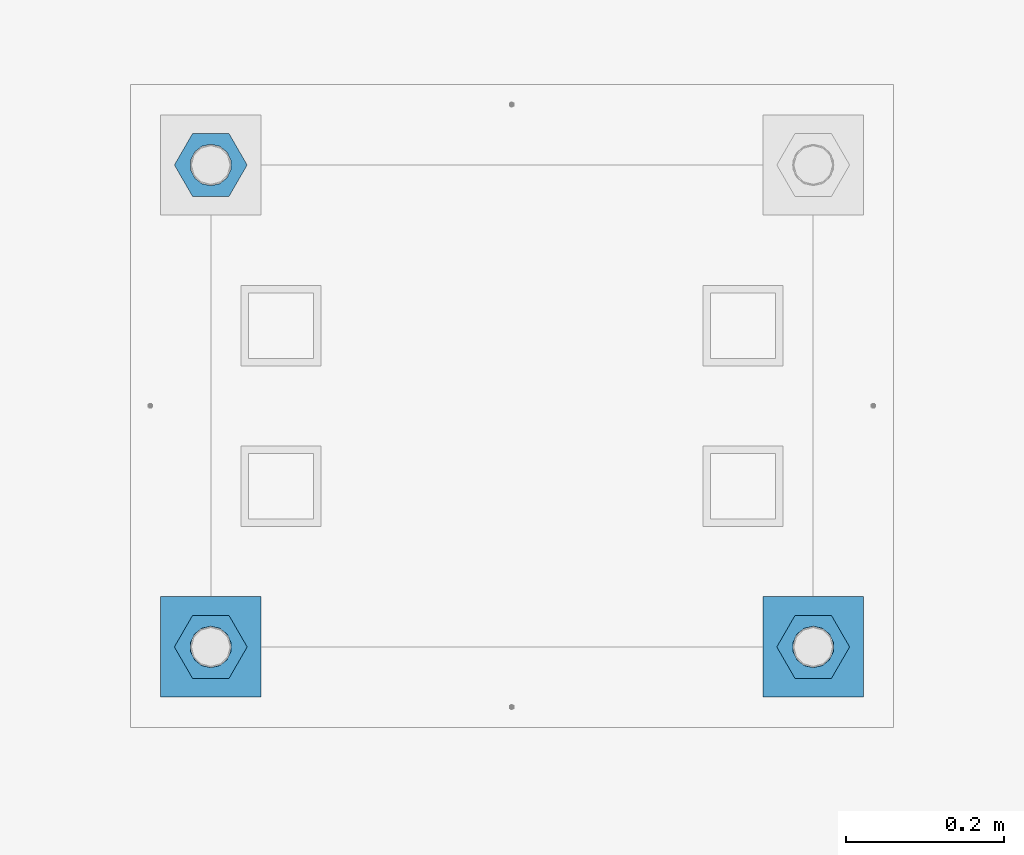
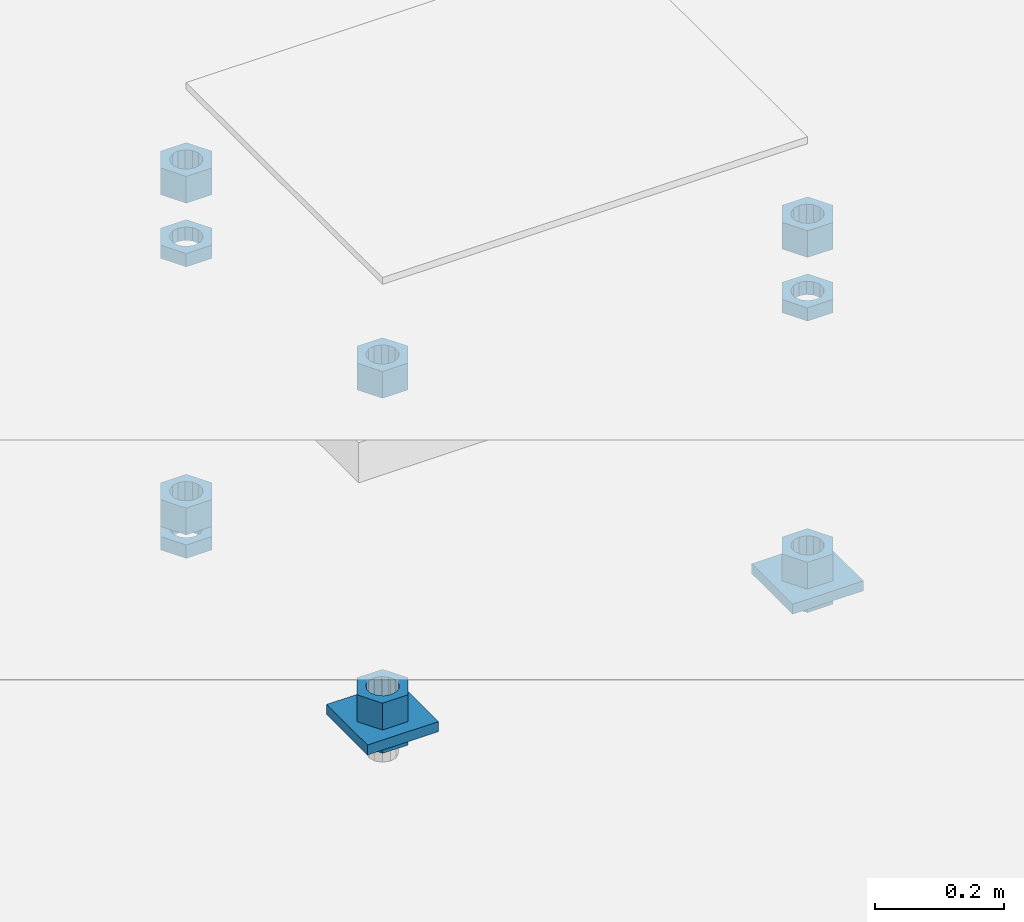
# One storey, part 2667 of 3843: 13 beams, 1 element without a shape of its own.
"""IFC2X3 building model written with IfcOpenShell, lengths in millimetres."""

import ifcopenshell
import ifcopenshell.guid

model = None  # the IFC model being written
_history = None  # IfcOwnerHistory: only IFC2X3 demands one
_inside = {}  # id of a spatial element -> (the spatial element, [elements in it])
_under = {}  # id of a project, library or spatial element -> (it, [spatial elements below it])
_declared = {}  # id of a project -> (the project, [libraries it declares])
_typed = {}  # id of a type object -> (the type object, [elements of that type])
_made_of = {}  # id of a material, layer set ... -> (it, [elements and type objects made of it])


def new_model(schema):
    """Start an empty IFC model of exactly this schema.

    Asked for "IFC4X3", IfcOpenShell would pick the latest addendum, in which some entities
    have other attributes; the version numbers below select the first issue.
    IFC2X3 requires an IfcOwnerHistory on every rooted entity: one is made here for all.
    """
    global model, _history
    if schema == "IFC4X3":
        model = ifcopenshell.file(schema_version=(4, 3, 0, 0))
    else:
        model = ifcopenshell.file(schema=schema)
    _inside.clear()
    _under.clear()
    _declared.clear()
    _typed.clear()
    _made_of.clear()
    _history = None
    if model.schema == "IFC2X3":
        org = make("IfcOrganization", Name="unknown")
        user = make(
            "IfcPersonAndOrganization",
            ThePerson=make("IfcPerson", FamilyName="unknown"),
            TheOrganization=org,
        )
        app = make(
            "IfcApplication",
            ApplicationDeveloper=org,
            Version="unknown",
            ApplicationFullName="unknown",
            ApplicationIdentifier="unknown",
        )
        _history = make(
            "IfcOwnerHistory",
            OwningUser=user,
            OwningApplication=app,
            ChangeAction="ADDED",
            CreationDate=0,
        )
    return model


def make(cls, **values):
    """One entity of the class cls with the attributes given. An attribute that is None is left unset."""
    return model.create_entity(
        cls, **{name: value for name, value in values.items() if value is not None}
    )


def rooted(cls, **values):
    """An entity with a GlobalId (a new one), such as an element, a storey or a relation."""
    return make(cls, GlobalId=ifcopenshell.guid.new(), OwnerHistory=_history, **values)


def si_unit(unit_type, name, prefix=None):
    """IfcSIUnit, for example si_unit("LENGTHUNIT", "METRE", prefix="MILLI")."""
    return make("IfcSIUnit", UnitType=unit_type, Prefix=prefix, Name=name)


def assignment(units):
    """IfcUnitAssignment: the units of a project."""
    return None if units is None else make("IfcUnitAssignment", Units=units)


def point(xyz):
    """IfcCartesianPoint."""
    return None if xyz is None else make("IfcCartesianPoint", Coordinates=xyz)


def direction(xyz):
    """IfcDirection."""
    return None if xyz is None else make("IfcDirection", DirectionRatios=xyz)


def frame(location, z_axis=None, x_axis=None):
    """IfcAxis2Placement3D, a coordinate frame: its origin and axes. An axis left out is left unset."""
    return make(
        "IfcAxis2Placement3D",
        Location=point(location),
        Axis=direction(z_axis),
        RefDirection=direction(x_axis),
    )


def origin_with_axes():
    """The frame at (0, 0, 0) with the z axis (0, 0, 1) and the x axis (1, 0, 0) written out."""
    return frame((0.0, 0.0, 0.0), z_axis=(0.0, 0.0, 1.0), x_axis=(1.0, 0.0, 0.0))


def place(relative_to, where):
    """IfcLocalPlacement: puts the frame where relative to a parent placement (None: the world)."""
    return make(
        "IfcLocalPlacement", PlacementRelTo=relative_to, RelativePlacement=where
    )


def context(
    kind, dimensions, precision=None, world=None, true_north=None, identifier=None
):
    """IfcGeometricRepresentationContext, for example the 3D "Model" context."""
    return make(
        "IfcGeometricRepresentationContext",
        ContextIdentifier=identifier,
        ContextType=kind,
        CoordinateSpaceDimension=dimensions,
        Precision=precision,
        WorldCoordinateSystem=world,
        TrueNorth=true_north,
    )


def subcontext(parent, identifier, kind, view, scale=None):
    """IfcGeometricRepresentationSubContext, for example "Body" below "Model"."""
    return make(
        "IfcGeometricRepresentationSubContext",
        ContextIdentifier=identifier,
        ContextType=kind,
        ParentContext=parent,
        TargetScale=scale,
        TargetView=view,
    )


def project(units=None, contexts=None):
    """IfcProject with its units and contexts."""
    return rooted(
        "IfcProject",
        Name="project",
        RepresentationContexts=contexts,
        UnitsInContext=assignment(units),
    )


def spatial(cls, under=None, at=None, **own):
    """A site, building, storey or space (cls), placed at a placement, below another one or the project."""
    s = rooted(cls, ObjectPlacement=at, **own)
    if under is not None:
        _under.setdefault(under.id(), (under, []))[1].append(s)
    return s


def faces_of(points, faces, orient=None, outer=None):
    """IfcFace entities. A face is a list of loops; a loop is a list of indices into points, from 0.

    orient and outer hold one flag for each loop. By default every Orientation is true, the
    first loop of a face is its IfcFaceOuterBound and the others are IfcFaceBound.
    """
    made = []
    for i, loops in enumerate(faces):
        bounds = []
        for j, loop in enumerate(loops):
            is_outer = j == 0 if outer is None else outer[i][j]
            bounds.append(
                make(
                    "IfcFaceOuterBound" if is_outer else "IfcFaceBound",
                    Bound=make("IfcPolyLoop", Polygon=[points[k] for k in loop]),
                    Orientation=True if orient is None else orient[i][j],
                )
            )
        made.append(make("IfcFace", Bounds=bounds))
    return made


def faceted_brep(points, faces, orient=None, outer=None, voids=None):
    """IfcFacetedBrep: a solid bounded by flat faces; with voids (closed shells), ...WithVoids."""
    shared = [point(p) for p in points]
    hull = make("IfcClosedShell", CfsFaces=faces_of(shared, faces, orient, outer))
    if voids is None:
        return make("IfcFacetedBrep", Outer=hull)
    return make(
        "IfcFacetedBrepWithVoids",
        Outer=hull,
        Voids=[
            make(cls, CfsFaces=faces_of(shared, fs, o, b)) for cls, fs, o, b in voids
        ],
    )


def shape(context_of_items, identifier, shape_type, items):
    """IfcShapeRepresentation: the items that make up one representation, for example the "Body"."""
    return make(
        "IfcShapeRepresentation",
        ContextOfItems=context_of_items,
        RepresentationIdentifier=identifier,
        RepresentationType=shape_type,
        Items=items,
    )


def material(Name=None, Category=None):
    """IfcMaterial."""
    return make("IfcMaterial", Name=Name, Category=Category)


def made_of(thing, what):
    """Note that an element or type object is made of a material, layer set ...; save() writes the relation."""
    if what is not None:
        _made_of.setdefault(what.id(), (what, []))[1].append(thing)
    return thing


def type_object(cls, material=None, **own):
    """A type object (cls), such as IfcWallType, which elements share."""
    return made_of(rooted(cls, **own), material)


def element(
    cls,
    number,
    at=None,
    inside=None,
    cuts=None,
    type_object=None,
    material=None,
    context=None,
    identifier="Body",
    shape_type=None,
    held_by="IfcProductDefinitionShape",
    body=None,
    shapes=None,
    **own,
):
    """One element of the class cls, such as IfcWall. Its Tag is "e" and its number.

    at: its placement. inside: the storey or other place that contains it. cuts: it is an
    opening in that element (IfcRelVoidsElement). A single representation is given by context,
    identifier, shape_type and body (its items); several are given by shapes. held_by: the class
    of the entity that holds the representations. save() writes the other relations.
    """
    e = rooted(cls, Tag="e%d" % number, ObjectPlacement=at, **own)
    if body is not None:
        shapes = [shape(context, identifier, shape_type, body)]
    if shapes is not None:
        e.Representation = make(held_by, Representations=shapes)
    if inside is not None:
        _inside.setdefault(inside.id(), (inside, []))[1].append(e)
    if cuts is not None:
        rooted(
            "IfcRelVoidsElement", RelatingBuildingElement=cuts, RelatedOpeningElement=e
        )
    if type_object is not None:
        _typed.setdefault(type_object.id(), (type_object, []))[1].append(e)
    return made_of(e, material)


def aggregate(whole, parts):
    """IfcRelAggregates: a whole, such as a stair, and the parts it consists of."""
    return rooted("IfcRelAggregates", RelatingObject=whole, RelatedObjects=parts)


def save(model, path):
    """Write the relations noted so far, then the file.

    IfcRelAggregates (storeys below a building ...), IfcRelContainedInSpatialStructure (elements
    in a storey), IfcRelDefinesByType, IfcRelAssociatesMaterial and IfcRelDeclares: one each for
    every whole, place, type object, material and project.
    """
    for whole, parts in _under.values():
        aggregate(whole, parts)
    for where, things in _inside.values():
        rooted(
            "IfcRelContainedInSpatialStructure",
            RelatedElements=things,
            RelatingStructure=where,
        )
    for kind, things in _typed.values():
        rooted("IfcRelDefinesByType", RelatedObjects=things, RelatingType=kind)
    for what, things in _made_of.values():
        rooted("IfcRelAssociatesMaterial", RelatedObjects=things, RelatingMaterial=what)
    for by, libraries in _declared.values():
        rooted("IfcRelDeclares", RelatingContext=by, RelatedDefinitions=libraries)
    model.write(path)


model = new_model("IFC2X3")

# Units and contexts
model_context = context("Model", 3, precision=1e-05, world=origin_with_axes())
body_context = subcontext(model_context, "Body", "Model", "MODEL_VIEW")
ifc_project = project(units=[si_unit("LENGTHUNIT", "METRE", prefix="MILLI"), si_unit("AREAUNIT", "SQUARE_METRE"), si_unit("VOLUMEUNIT", "CUBIC_METRE"), si_unit("MASSUNIT", "GRAM", prefix="KILO"), si_unit("TIMEUNIT", "SECOND"), si_unit("PLANEANGLEUNIT", "RADIAN"), si_unit("SOLIDANGLEUNIT", "STERADIAN"), si_unit("THERMODYNAMICTEMPERATUREUNIT", "DEGREE_CELSIUS"), si_unit("LUMINOUSINTENSITYUNIT", "LUMEN")], contexts=[model_context])

# Site, building, storey
site_placement = place(None, origin_with_axes())
site = spatial("IfcSite", under=ifc_project, at=site_placement, CompositionType="ELEMENT")
building_placement = place(site_placement, origin_with_axes())
building = spatial("IfcBuilding", under=site, at=building_placement, Name="Undefined", CompositionType="ELEMENT")
storey_placement = place(building_placement, origin_with_axes())
storey = spatial("IfcBuildingStorey", under=building, at=storey_placement, Name="Undefined", CompositionType="ELEMENT", Elevation=0.0)

# Assembly, beams
assembly_placement = place(storey_placement, origin_with_axes())
assembly = element("IfcElementAssembly", 1, at=assembly_placement, inside=storey, Name="TEMPLATE", AssemblyPlace="NOTDEFINED", PredefinedType="RIGID_FRAME")
ifc_material_1 = material(Name="STEEL/A572-50")
beam_type_1 = type_object("IfcBeamType", PredefinedType="NOTDEFINED")
beam_1_placement = place(assembly_placement, frame((118465.6, 21717.0000015259, 29244.925), z_axis=(1.0, 0.0, 0.0), x_axis=(0.0, 1.0, 0.0)))
beam_1 = element("IfcBeam", 2, at=beam_1_placement, type_object=beam_type_1, material=ifc_material_1, Name="WASHER_PLATE", context=body_context, shape_type="Brep", body=[
    faceted_brep([(0.0, 9.52500000000146, -63.5), (0.0, 9.52500000000146, 63.5), (127.0, 9.52500000000146, 63.5), (127.0, 9.52500000000146, -63.5), (0.0, -9.52500000000146, 63.5), (127.0, -9.52500000000146, 63.5), (0.0, -9.52500000000146, -63.5), (127.0, -9.52500000000146, -63.5)], [[[0, 1, 2, 3]], [[1, 4, 5, 2]], [[4, 6, 7, 5]], [[6, 0, 3, 7]], [[5, 7, 3, 2]], [[6, 4, 1, 0]]]),
])
beam_2_placement = place(assembly_placement, frame((119227.6, 21717.0000015259, 29244.925), z_axis=(1.0, 0.0, 0.0), x_axis=(0.0, 1.0, 0.0)))
beam_2 = element("IfcBeam", 3, at=beam_2_placement, type_object=beam_type_1, material=ifc_material_1, Name="WASHER_PLATE", context=body_context, shape_type="Brep", body=[
    faceted_brep([(0.0, 9.52500000000146, -63.5), (0.0, 9.52500000000146, 63.5), (127.0, 9.52500000000146, 63.5), (127.0, 9.52500000000146, -63.5), (0.0, -9.52500000000146, 63.5), (127.0, -9.52500000000146, 63.5), (0.0, -9.52500000000146, -63.5), (127.0, -9.52500000000146, -63.5)], [[[0, 1, 2, 3]], [[1, 4, 5, 2]], [[4, 6, 7, 5]], [[6, 0, 3, 7]], [[5, 7, 3, 2]], [[6, 4, 1, 0]]]),
])
ifc_material_2 = material(Name="STEEL/A36")
beam_type_2 = type_object("IfcBeamType", Name="2_HALF_NUT", PredefinedType="NOTDEFINED")
beam_3_placement = place(assembly_placement, frame((118465.6, 21780.5000015259, 29235.4), z_axis=(0.0, 1.0, 0.0), x_axis=(0.0, 0.0, -1.0)))
beam_3 = element("IfcBeam", 4, at=beam_3_placement, type_object=beam_type_2, material=ifc_material_2, Name="NUT", ObjectType="2_HALF_NUT", context=body_context, shape_type="Brep", body=[
    faceted_brep([(0.0, -46.0369987487793, 0.0), (0.0, -23.0184993743896, -39.869213104248), (25.4000000000015, -23.0184993743896, -39.869213104248), (25.4000000000015, -46.0369987487793, 0.0), (0.0, 23.0184993743896, -39.869213104248), (25.4000000000015, 23.0184993743896, -39.869213104248), (0.0, 46.0369987487793, 0.0), (25.4000000000015, 46.0369987487793, 0.0), (0.0, 23.0184993743896, 39.869213104248), (25.4000000000015, 23.0184993743896, 39.869213104248), (0.0, -23.0184993743896, 39.869213104248), (25.4000000000015, -23.0184993743896, 39.869213104248), (0.0, 0.0, 26.1940002441406), (0.0, 11.3650617044477, 23.5999013092805), (25.4000000000015, 11.3650617044477, 23.5999013092805), (25.4000000000015, 0.0, 26.1940002441406), (0.0, 20.4791109456419, 16.3316083006721), (25.4000000000015, 20.4791109456419, 16.3316083006721), (0.0, 25.5370200498292, 5.82867859874386), (25.4000000000015, 25.5370200498292, 5.82867859874386), (0.0, 25.5370200498292, -5.82867859874386), (25.4000000000015, 25.5370200498292, -5.82867859874386), (0.0, 20.4791109456419, -16.3316083006721), (25.4000000000015, 20.4791109456419, -16.3316083006721), (0.0, 11.3650617044477, -23.5999013092805), (25.4000000000015, 11.3650617044477, -23.5999013092805), (0.0, 0.0, -26.1940002441406), (25.4000000000015, 0.0, -26.1940002441406), (0.0, -11.3650617044477, -23.5999013092805), (25.4000000000015, -11.3650617044477, -23.5999013092805), (0.0, -20.4791109456419, -16.3316083006721), (25.4000000000015, -20.4791109456419, -16.3316083006721), (0.0, -25.5370200498292, -5.82867859874386), (25.4000000000015, -25.5370200498292, -5.82867859874386), (0.0, -25.5370200498292, 5.82867859874386), (25.4000000000015, -25.5370200498292, 5.82867859874386), (0.0, -20.4791109456419, 16.3316083006721), (25.4000000000015, -20.4791109456419, 16.3316083006721), (0.0, -11.3650617044477, 23.5999013092805), (25.4000000000015, -11.3650617044477, 23.5999013092805)], [[[0, 1, 2, 3]], [[1, 4, 5, 2]], [[4, 6, 7, 5]], [[6, 8, 9, 7]], [[8, 10, 11, 9]], [[10, 0, 3, 11]], [[12, 13, 14, 15]], [[13, 16, 17, 14]], [[16, 18, 19, 17]], [[18, 20, 21, 19]], [[20, 22, 23, 21]], [[22, 24, 25, 23]], [[24, 26, 27, 25]], [[26, 28, 29, 27]], [[28, 30, 31, 29]], [[30, 32, 33, 31]], [[32, 34, 35, 33]], [[34, 36, 37, 35]], [[36, 38, 39, 37]], [[38, 12, 15, 39]], [[5, 7, 9, 11, 3, 2], [17, 19, 21, 23, 25, 27, 29, 31, 33, 35, 37, 39, 15, 14]], [[10, 8, 6, 4, 1, 0], [38, 36, 34, 32, 30, 28, 26, 24, 22, 20, 18, 16, 13, 12]]]),
])
beam_4_placement = place(assembly_placement, frame((119227.6, 21780.5000015259, 29787.85), z_axis=(0.0, 1.0, 0.0), x_axis=(0.0, 0.0, -1.0)))
beam_4 = element("IfcBeam", 5, at=beam_4_placement, type_object=beam_type_2, material=ifc_material_2, Name="NUT", ObjectType="2_HALF_NUT", context=body_context, shape_type="Brep", body=[
    faceted_brep([(0.0, -46.0369987487793, 0.0), (0.0, -23.0184993743896, -39.869213104248), (25.4000000000015, -23.0184993743896, -39.869213104248), (25.4000000000015, -46.0369987487793, 0.0), (0.0, 23.0184993743896, -39.869213104248), (25.4000000000015, 23.0184993743896, -39.869213104248), (0.0, 46.0369987487793, 0.0), (25.4000000000015, 46.0369987487793, 0.0), (0.0, 23.0184993743896, 39.869213104248), (25.4000000000015, 23.0184993743896, 39.869213104248), (0.0, -23.0184993743896, 39.869213104248), (25.4000000000015, -23.0184993743896, 39.869213104248), (0.0, 0.0, 26.1940002441406), (0.0, 11.3650617044477, 23.5999013092805), (25.4000000000015, 11.3650617044477, 23.5999013092805), (25.4000000000015, 0.0, 26.1940002441406), (0.0, 20.4791109456419, 16.3316083006721), (25.4000000000015, 20.4791109456419, 16.3316083006721), (0.0, 25.5370200498292, 5.82867859874386), (25.4000000000015, 25.5370200498292, 5.82867859874386), (0.0, 25.5370200498292, -5.82867859874386), (25.4000000000015, 25.5370200498292, -5.82867859874386), (0.0, 20.4791109456419, -16.3316083006721), (25.4000000000015, 20.4791109456419, -16.3316083006721), (0.0, 11.3650617044477, -23.5999013092805), (25.4000000000015, 11.3650617044477, -23.5999013092805), (0.0, 0.0, -26.1940002441406), (25.4000000000015, 0.0, -26.1940002441406), (0.0, -11.3650617044477, -23.5999013092805), (25.4000000000015, -11.3650617044477, -23.5999013092805), (0.0, -20.4791109456419, -16.3316083006721), (25.4000000000015, -20.4791109456419, -16.3316083006721), (0.0, -25.5370200498292, -5.82867859874386), (25.4000000000015, -25.5370200498292, -5.82867859874386), (0.0, -25.5370200498292, 5.82867859874386), (25.4000000000015, -25.5370200498292, 5.82867859874386), (0.0, -20.4791109456419, 16.3316083006721), (25.4000000000015, -20.4791109456419, 16.3316083006721), (0.0, -11.3650617044477, 23.5999013092805), (25.4000000000015, -11.3650617044477, 23.5999013092805)], [[[0, 1, 2, 3]], [[1, 4, 5, 2]], [[4, 6, 7, 5]], [[6, 8, 9, 7]], [[8, 10, 11, 9]], [[10, 0, 3, 11]], [[12, 13, 14, 15]], [[13, 16, 17, 14]], [[16, 18, 19, 17]], [[18, 20, 21, 19]], [[20, 22, 23, 21]], [[22, 24, 25, 23]], [[24, 26, 27, 25]], [[26, 28, 29, 27]], [[28, 30, 31, 29]], [[30, 32, 33, 31]], [[32, 34, 35, 33]], [[34, 36, 37, 35]], [[36, 38, 39, 37]], [[38, 12, 15, 39]], [[5, 7, 9, 11, 3, 2], [17, 19, 21, 23, 25, 27, 29, 31, 33, 35, 37, 39, 15, 14]], [[10, 8, 6, 4, 1, 0], [38, 36, 34, 32, 30, 28, 26, 24, 22, 20, 18, 16, 13, 12]]]),
])
beam_5_placement = place(assembly_placement, frame((119227.6, 21780.5000015259, 29235.4), z_axis=(0.0, 1.0, 0.0), x_axis=(0.0, 0.0, -1.0)))
beam_5 = element("IfcBeam", 6, at=beam_5_placement, type_object=beam_type_2, material=ifc_material_2, Name="NUT", ObjectType="2_HALF_NUT", context=body_context, shape_type="Brep", body=[
    faceted_brep([(0.0, -46.0369987487793, 0.0), (0.0, -23.0184993743896, -39.869213104248), (25.4000000000015, -23.0184993743896, -39.869213104248), (25.4000000000015, -46.0369987487793, 0.0), (0.0, 23.0184993743896, -39.869213104248), (25.4000000000015, 23.0184993743896, -39.869213104248), (0.0, 46.0369987487793, 0.0), (25.4000000000015, 46.0369987487793, 0.0), (0.0, 23.0184993743896, 39.869213104248), (25.4000000000015, 23.0184993743896, 39.869213104248), (0.0, -23.0184993743896, 39.869213104248), (25.4000000000015, -23.0184993743896, 39.869213104248), (0.0, 0.0, 26.1940002441406), (0.0, 11.3650617044477, 23.5999013092805), (25.4000000000015, 11.3650617044477, 23.5999013092805), (25.4000000000015, 0.0, 26.1940002441406), (0.0, 20.4791109456419, 16.3316083006721), (25.4000000000015, 20.4791109456419, 16.3316083006721), (0.0, 25.5370200498292, 5.82867859874386), (25.4000000000015, 25.5370200498292, 5.82867859874386), (0.0, 25.5370200498292, -5.82867859874386), (25.4000000000015, 25.5370200498292, -5.82867859874386), (0.0, 20.4791109456419, -16.3316083006721), (25.4000000000015, 20.4791109456419, -16.3316083006721), (0.0, 11.3650617044477, -23.5999013092805), (25.4000000000015, 11.3650617044477, -23.5999013092805), (0.0, 0.0, -26.1940002441406), (25.4000000000015, 0.0, -26.1940002441406), (0.0, -11.3650617044477, -23.5999013092805), (25.4000000000015, -11.3650617044477, -23.5999013092805), (0.0, -20.4791109456419, -16.3316083006721), (25.4000000000015, -20.4791109456419, -16.3316083006721), (0.0, -25.5370200498292, -5.82867859874386), (25.4000000000015, -25.5370200498292, -5.82867859874386), (0.0, -25.5370200498292, 5.82867859874386), (25.4000000000015, -25.5370200498292, 5.82867859874386), (0.0, -20.4791109456419, 16.3316083006721), (25.4000000000015, -20.4791109456419, 16.3316083006721), (0.0, -11.3650617044477, 23.5999013092805), (25.4000000000015, -11.3650617044477, 23.5999013092805)], [[[0, 1, 2, 3]], [[1, 4, 5, 2]], [[4, 6, 7, 5]], [[6, 8, 9, 7]], [[8, 10, 11, 9]], [[10, 0, 3, 11]], [[12, 13, 14, 15]], [[13, 16, 17, 14]], [[16, 18, 19, 17]], [[18, 20, 21, 19]], [[20, 22, 23, 21]], [[22, 24, 25, 23]], [[24, 26, 27, 25]], [[26, 28, 29, 27]], [[28, 30, 31, 29]], [[30, 32, 33, 31]], [[32, 34, 35, 33]], [[34, 36, 37, 35]], [[36, 38, 39, 37]], [[38, 12, 15, 39]], [[5, 7, 9, 11, 3, 2], [17, 19, 21, 23, 25, 27, 29, 31, 33, 35, 37, 39, 15, 14]], [[10, 8, 6, 4, 1, 0], [38, 36, 34, 32, 30, 28, 26, 24, 22, 20, 18, 16, 13, 12]]]),
])
beam_6_placement = place(assembly_placement, frame((118465.6, 22390.1000015259, 29787.85), z_axis=(0.0, 1.0, 0.0), x_axis=(0.0, 0.0, -1.0)))
beam_6 = element("IfcBeam", 7, at=beam_6_placement, type_object=beam_type_2, material=ifc_material_2, Name="NUT", ObjectType="2_HALF_NUT", context=body_context, shape_type="Brep", body=[
    faceted_brep([(0.0, -46.0369987487793, 0.0), (0.0, -23.0184993743896, -39.869213104248), (25.4000000000015, -23.0184993743896, -39.869213104248), (25.4000000000015, -46.0369987487793, 0.0), (0.0, 23.0184993743896, -39.869213104248), (25.4000000000015, 23.0184993743896, -39.869213104248), (0.0, 46.0369987487793, 0.0), (25.4000000000015, 46.0369987487793, 0.0), (0.0, 23.0184993743896, 39.869213104248), (25.4000000000015, 23.0184993743896, 39.869213104248), (0.0, -23.0184993743896, 39.869213104248), (25.4000000000015, -23.0184993743896, 39.869213104248), (0.0, 0.0, 26.1940002441406), (0.0, 11.3650617044477, 23.5999013092805), (25.4000000000015, 11.3650617044477, 23.5999013092805), (25.4000000000015, 0.0, 26.1940002441406), (0.0, 20.4791109456419, 16.3316083006721), (25.4000000000015, 20.4791109456419, 16.3316083006721), (0.0, 25.5370200498292, 5.82867859874386), (25.4000000000015, 25.5370200498292, 5.82867859874386), (0.0, 25.5370200498292, -5.82867859874386), (25.4000000000015, 25.5370200498292, -5.82867859874386), (0.0, 20.4791109456419, -16.3316083006721), (25.4000000000015, 20.4791109456419, -16.3316083006721), (0.0, 11.3650617044477, -23.5999013092805), (25.4000000000015, 11.3650617044477, -23.5999013092805), (0.0, 0.0, -26.1940002441406), (25.4000000000015, 0.0, -26.1940002441406), (0.0, -11.3650617044477, -23.5999013092805), (25.4000000000015, -11.3650617044477, -23.5999013092805), (0.0, -20.4791109456419, -16.3316083006721), (25.4000000000015, -20.4791109456419, -16.3316083006721), (0.0, -25.5370200498292, -5.82867859874386), (25.4000000000015, -25.5370200498292, -5.82867859874386), (0.0, -25.5370200498292, 5.82867859874386), (25.4000000000015, -25.5370200498292, 5.82867859874386), (0.0, -20.4791109456419, 16.3316083006721), (25.4000000000015, -20.4791109456419, 16.3316083006721), (0.0, -11.3650617044477, 23.5999013092805), (25.4000000000015, -11.3650617044477, 23.5999013092805)], [[[0, 1, 2, 3]], [[1, 4, 5, 2]], [[4, 6, 7, 5]], [[6, 8, 9, 7]], [[8, 10, 11, 9]], [[10, 0, 3, 11]], [[12, 13, 14, 15]], [[13, 16, 17, 14]], [[16, 18, 19, 17]], [[18, 20, 21, 19]], [[20, 22, 23, 21]], [[22, 24, 25, 23]], [[24, 26, 27, 25]], [[26, 28, 29, 27]], [[28, 30, 31, 29]], [[30, 32, 33, 31]], [[32, 34, 35, 33]], [[34, 36, 37, 35]], [[36, 38, 39, 37]], [[38, 12, 15, 39]], [[5, 7, 9, 11, 3, 2], [17, 19, 21, 23, 25, 27, 29, 31, 33, 35, 37, 39, 15, 14]], [[10, 8, 6, 4, 1, 0], [38, 36, 34, 32, 30, 28, 26, 24, 22, 20, 18, 16, 13, 12]]]),
])
beam_7_placement = place(assembly_placement, frame((118465.6, 22390.1000015259, 29235.4), z_axis=(0.0, 1.0, 0.0), x_axis=(0.0, 0.0, -1.0)))
beam_7 = element("IfcBeam", 8, at=beam_7_placement, type_object=beam_type_2, material=ifc_material_2, Name="NUT", ObjectType="2_HALF_NUT", context=body_context, shape_type="Brep", body=[
    faceted_brep([(0.0, -46.0369987487793, 0.0), (0.0, -23.0184993743896, -39.869213104248), (25.4000000000015, -23.0184993743896, -39.869213104248), (25.4000000000015, -46.0369987487793, 0.0), (0.0, 23.0184993743896, -39.869213104248), (25.4000000000015, 23.0184993743896, -39.869213104248), (0.0, 46.0369987487793, 0.0), (25.4000000000015, 46.0369987487793, 0.0), (0.0, 23.0184993743896, 39.869213104248), (25.4000000000015, 23.0184993743896, 39.869213104248), (0.0, -23.0184993743896, 39.869213104248), (25.4000000000015, -23.0184993743896, 39.869213104248), (0.0, 0.0, 26.1940002441406), (0.0, 11.3650617044477, 23.5999013092805), (25.4000000000015, 11.3650617044477, 23.5999013092805), (25.4000000000015, 0.0, 26.1940002441406), (0.0, 20.4791109456419, 16.3316083006721), (25.4000000000015, 20.4791109456419, 16.3316083006721), (0.0, 25.5370200498292, 5.82867859874386), (25.4000000000015, 25.5370200498292, 5.82867859874386), (0.0, 25.5370200498292, -5.82867859874386), (25.4000000000015, 25.5370200498292, -5.82867859874386), (0.0, 20.4791109456419, -16.3316083006721), (25.4000000000015, 20.4791109456419, -16.3316083006721), (0.0, 11.3650617044477, -23.5999013092805), (25.4000000000015, 11.3650617044477, -23.5999013092805), (0.0, 0.0, -26.1940002441406), (25.4000000000015, 0.0, -26.1940002441406), (0.0, -11.3650617044477, -23.5999013092805), (25.4000000000015, -11.3650617044477, -23.5999013092805), (0.0, -20.4791109456419, -16.3316083006721), (25.4000000000015, -20.4791109456419, -16.3316083006721), (0.0, -25.5370200498292, -5.82867859874386), (25.4000000000015, -25.5370200498292, -5.82867859874386), (0.0, -25.5370200498292, 5.82867859874386), (25.4000000000015, -25.5370200498292, 5.82867859874386), (0.0, -20.4791109456419, 16.3316083006721), (25.4000000000015, -20.4791109456419, 16.3316083006721), (0.0, -11.3650617044477, 23.5999013092805), (25.4000000000015, -11.3650617044477, 23.5999013092805)], [[[0, 1, 2, 3]], [[1, 4, 5, 2]], [[4, 6, 7, 5]], [[6, 8, 9, 7]], [[8, 10, 11, 9]], [[10, 0, 3, 11]], [[12, 13, 14, 15]], [[13, 16, 17, 14]], [[16, 18, 19, 17]], [[18, 20, 21, 19]], [[20, 22, 23, 21]], [[22, 24, 25, 23]], [[24, 26, 27, 25]], [[26, 28, 29, 27]], [[28, 30, 31, 29]], [[30, 32, 33, 31]], [[32, 34, 35, 33]], [[34, 36, 37, 35]], [[36, 38, 39, 37]], [[38, 12, 15, 39]], [[5, 7, 9, 11, 3, 2], [17, 19, 21, 23, 25, 27, 29, 31, 33, 35, 37, 39, 15, 14]], [[10, 8, 6, 4, 1, 0], [38, 36, 34, 32, 30, 28, 26, 24, 22, 20, 18, 16, 13, 12]]]),
])
beam_type_3 = type_object("IfcBeamType", Name="2_HEAVY_HEX_NUT", PredefinedType="NOTDEFINED")
beam_8_placement = place(assembly_placement, frame((118465.6, 21780.5000015259, 29933.9), z_axis=(0.0, 1.0, 0.0), x_axis=(0.0, 0.0, -1.0)))
beam_8 = element("IfcBeam", 9, at=beam_8_placement, type_object=beam_type_3, material=ifc_material_2, Name="NUT", ObjectType="2_HEAVY_HEX_NUT", context=body_context, shape_type="Brep", body=[
    faceted_brep([(0.0, -46.0369987487793, 0.0), (0.0, -23.0184993743896, -39.869213104248), (50.7999999999993, -23.0184993743896, -39.869213104248), (50.7999999999993, -46.0369987487793, 0.0), (0.0, 23.0184993743896, -39.869213104248), (50.7999999999993, 23.0184993743896, -39.869213104248), (0.0, 46.0369987487793, 0.0), (50.7999999999993, 46.0369987487793, 0.0), (0.0, 23.0184993743896, 39.869213104248), (50.7999999999993, 23.0184993743896, 39.869213104248), (0.0, -23.0184993743896, 39.869213104248), (50.7999999999993, -23.0184993743896, 39.869213104248), (0.0, 0.0, 26.1940002441406), (0.0, 11.3650617044477, 23.5999013092805), (50.7999999999993, 11.3650617044477, 23.5999013092805), (50.7999999999993, 0.0, 26.1940002441406), (0.0, 20.4791109456419, 16.3316083006721), (50.7999999999993, 20.4791109456419, 16.3316083006721), (0.0, 25.5370200498292, 5.82867859874386), (50.7999999999993, 25.5370200498292, 5.82867859874386), (0.0, 25.5370200498292, -5.82867859874386), (50.7999999999993, 25.5370200498292, -5.82867859874386), (0.0, 20.4791109456419, -16.3316083006721), (50.7999999999993, 20.4791109456419, -16.3316083006721), (0.0, 11.3650617044477, -23.5999013092805), (50.7999999999993, 11.3650617044477, -23.5999013092805), (0.0, 0.0, -26.1940002441406), (50.7999999999993, 0.0, -26.1940002441406), (0.0, -11.3650617044477, -23.5999013092805), (50.7999999999993, -11.3650617044477, -23.5999013092805), (0.0, -20.4791109456419, -16.3316083006721), (50.7999999999993, -20.4791109456419, -16.3316083006721), (0.0, -25.5370200498292, -5.82867859874386), (50.7999999999993, -25.5370200498292, -5.82867859874386), (0.0, -25.5370200498292, 5.82867859874386), (50.7999999999993, -25.5370200498292, 5.82867859874386), (0.0, -20.4791109456419, 16.3316083006721), (50.7999999999993, -20.4791109456419, 16.3316083006721), (0.0, -11.3650617044477, 23.5999013092805), (50.7999999999993, -11.3650617044477, 23.5999013092805)], [[[0, 1, 2, 3]], [[1, 4, 5, 2]], [[4, 6, 7, 5]], [[6, 8, 9, 7]], [[8, 10, 11, 9]], [[10, 0, 3, 11]], [[12, 13, 14, 15]], [[13, 16, 17, 14]], [[16, 18, 19, 17]], [[18, 20, 21, 19]], [[20, 22, 23, 21]], [[22, 24, 25, 23]], [[24, 26, 27, 25]], [[26, 28, 29, 27]], [[28, 30, 31, 29]], [[30, 32, 33, 31]], [[32, 34, 35, 33]], [[34, 36, 37, 35]], [[36, 38, 39, 37]], [[38, 12, 15, 39]], [[5, 7, 9, 11, 3, 2], [17, 19, 21, 23, 25, 27, 29, 31, 33, 35, 37, 39, 15, 14]], [[10, 8, 6, 4, 1, 0], [38, 36, 34, 32, 30, 28, 26, 24, 22, 20, 18, 16, 13, 12]]]),
])
beam_9_placement = place(assembly_placement, frame((118465.6, 21780.5000015259, 29305.25), z_axis=(0.0, 1.0, 0.0), x_axis=(0.0, 0.0, -1.0)))
beam_9 = element("IfcBeam", 10, at=beam_9_placement, type_object=beam_type_3, material=ifc_material_2, Name="NUT", ObjectType="2_HEAVY_HEX_NUT", context=body_context, shape_type="Brep", body=[
    faceted_brep([(0.0, -46.0369987487793, 0.0), (0.0, -23.0184993743896, -39.869213104248), (50.7999999999993, -23.0184993743896, -39.869213104248), (50.7999999999993, -46.0369987487793, 0.0), (0.0, 23.0184993743896, -39.869213104248), (50.7999999999993, 23.0184993743896, -39.869213104248), (0.0, 46.0369987487793, 0.0), (50.7999999999993, 46.0369987487793, 0.0), (0.0, 23.0184993743896, 39.869213104248), (50.7999999999993, 23.0184993743896, 39.869213104248), (0.0, -23.0184993743896, 39.869213104248), (50.7999999999993, -23.0184993743896, 39.869213104248), (0.0, 0.0, 26.1940002441406), (0.0, 11.3650617044477, 23.5999013092805), (50.7999999999993, 11.3650617044477, 23.5999013092805), (50.7999999999993, 0.0, 26.1940002441406), (0.0, 20.4791109456419, 16.3316083006721), (50.7999999999993, 20.4791109456419, 16.3316083006721), (0.0, 25.5370200498292, 5.82867859874386), (50.7999999999993, 25.5370200498292, 5.82867859874386), (0.0, 25.5370200498292, -5.82867859874386), (50.7999999999993, 25.5370200498292, -5.82867859874386), (0.0, 20.4791109456419, -16.3316083006721), (50.7999999999993, 20.4791109456419, -16.3316083006721), (0.0, 11.3650617044477, -23.5999013092805), (50.7999999999993, 11.3650617044477, -23.5999013092805), (0.0, 0.0, -26.1940002441406), (50.7999999999993, 0.0, -26.1940002441406), (0.0, -11.3650617044477, -23.5999013092805), (50.7999999999993, -11.3650617044477, -23.5999013092805), (0.0, -20.4791109456419, -16.3316083006721), (50.7999999999993, -20.4791109456419, -16.3316083006721), (0.0, -25.5370200498292, -5.82867859874386), (50.7999999999993, -25.5370200498292, -5.82867859874386), (0.0, -25.5370200498292, 5.82867859874386), (50.7999999999993, -25.5370200498292, 5.82867859874386), (0.0, -20.4791109456419, 16.3316083006721), (50.7999999999993, -20.4791109456419, 16.3316083006721), (0.0, -11.3650617044477, 23.5999013092805), (50.7999999999993, -11.3650617044477, 23.5999013092805)], [[[0, 1, 2, 3]], [[1, 4, 5, 2]], [[4, 6, 7, 5]], [[6, 8, 9, 7]], [[8, 10, 11, 9]], [[10, 0, 3, 11]], [[12, 13, 14, 15]], [[13, 16, 17, 14]], [[16, 18, 19, 17]], [[18, 20, 21, 19]], [[20, 22, 23, 21]], [[22, 24, 25, 23]], [[24, 26, 27, 25]], [[26, 28, 29, 27]], [[28, 30, 31, 29]], [[30, 32, 33, 31]], [[32, 34, 35, 33]], [[34, 36, 37, 35]], [[36, 38, 39, 37]], [[38, 12, 15, 39]], [[5, 7, 9, 11, 3, 2], [17, 19, 21, 23, 25, 27, 29, 31, 33, 35, 37, 39, 15, 14]], [[10, 8, 6, 4, 1, 0], [38, 36, 34, 32, 30, 28, 26, 24, 22, 20, 18, 16, 13, 12]]]),
])
beam_10_placement = place(assembly_placement, frame((119227.6, 21780.5000015259, 29933.9), z_axis=(0.0, 1.0, 0.0), x_axis=(0.0, 0.0, -1.0)))
beam_10 = element("IfcBeam", 11, at=beam_10_placement, type_object=beam_type_3, material=ifc_material_2, Name="NUT", ObjectType="2_HEAVY_HEX_NUT", context=body_context, shape_type="Brep", body=[
    faceted_brep([(0.0, -46.0369987487793, 0.0), (0.0, -23.0184993743896, -39.869213104248), (50.7999999999993, -23.0184993743896, -39.869213104248), (50.7999999999993, -46.0369987487793, 0.0), (0.0, 23.0184993743896, -39.869213104248), (50.7999999999993, 23.0184993743896, -39.869213104248), (0.0, 46.0369987487793, 0.0), (50.7999999999993, 46.0369987487793, 0.0), (0.0, 23.0184993743896, 39.869213104248), (50.7999999999993, 23.0184993743896, 39.869213104248), (0.0, -23.0184993743896, 39.869213104248), (50.7999999999993, -23.0184993743896, 39.869213104248), (0.0, 0.0, 26.1940002441406), (0.0, 11.3650617044477, 23.5999013092805), (50.7999999999993, 11.3650617044477, 23.5999013092805), (50.7999999999993, 0.0, 26.1940002441406), (0.0, 20.4791109456419, 16.3316083006721), (50.7999999999993, 20.4791109456419, 16.3316083006721), (0.0, 25.5370200498292, 5.82867859874386), (50.7999999999993, 25.5370200498292, 5.82867859874386), (0.0, 25.5370200498292, -5.82867859874386), (50.7999999999993, 25.5370200498292, -5.82867859874386), (0.0, 20.4791109456419, -16.3316083006721), (50.7999999999993, 20.4791109456419, -16.3316083006721), (0.0, 11.3650617044477, -23.5999013092805), (50.7999999999993, 11.3650617044477, -23.5999013092805), (0.0, 0.0, -26.1940002441406), (50.7999999999993, 0.0, -26.1940002441406), (0.0, -11.3650617044477, -23.5999013092805), (50.7999999999993, -11.3650617044477, -23.5999013092805), (0.0, -20.4791109456419, -16.3316083006721), (50.7999999999993, -20.4791109456419, -16.3316083006721), (0.0, -25.5370200498292, -5.82867859874386), (50.7999999999993, -25.5370200498292, -5.82867859874386), (0.0, -25.5370200498292, 5.82867859874386), (50.7999999999993, -25.5370200498292, 5.82867859874386), (0.0, -20.4791109456419, 16.3316083006721), (50.7999999999993, -20.4791109456419, 16.3316083006721), (0.0, -11.3650617044477, 23.5999013092805), (50.7999999999993, -11.3650617044477, 23.5999013092805)], [[[0, 1, 2, 3]], [[1, 4, 5, 2]], [[4, 6, 7, 5]], [[6, 8, 9, 7]], [[8, 10, 11, 9]], [[10, 0, 3, 11]], [[12, 13, 14, 15]], [[13, 16, 17, 14]], [[16, 18, 19, 17]], [[18, 20, 21, 19]], [[20, 22, 23, 21]], [[22, 24, 25, 23]], [[24, 26, 27, 25]], [[26, 28, 29, 27]], [[28, 30, 31, 29]], [[30, 32, 33, 31]], [[32, 34, 35, 33]], [[34, 36, 37, 35]], [[36, 38, 39, 37]], [[38, 12, 15, 39]], [[5, 7, 9, 11, 3, 2], [17, 19, 21, 23, 25, 27, 29, 31, 33, 35, 37, 39, 15, 14]], [[10, 8, 6, 4, 1, 0], [38, 36, 34, 32, 30, 28, 26, 24, 22, 20, 18, 16, 13, 12]]]),
])
beam_11_placement = place(assembly_placement, frame((119227.6, 21780.5000015259, 29305.25), z_axis=(0.0, 1.0, 0.0), x_axis=(0.0, 0.0, -1.0)))
beam_11 = element("IfcBeam", 12, at=beam_11_placement, type_object=beam_type_3, material=ifc_material_2, Name="NUT", ObjectType="2_HEAVY_HEX_NUT", context=body_context, shape_type="Brep", body=[
    faceted_brep([(0.0, -46.0369987487793, 0.0), (0.0, -23.0184993743896, -39.869213104248), (50.7999999999993, -23.0184993743896, -39.869213104248), (50.7999999999993, -46.0369987487793, 0.0), (0.0, 23.0184993743896, -39.869213104248), (50.7999999999993, 23.0184993743896, -39.869213104248), (0.0, 46.0369987487793, 0.0), (50.7999999999993, 46.0369987487793, 0.0), (0.0, 23.0184993743896, 39.869213104248), (50.7999999999993, 23.0184993743896, 39.869213104248), (0.0, -23.0184993743896, 39.869213104248), (50.7999999999993, -23.0184993743896, 39.869213104248), (0.0, 0.0, 26.1940002441406), (0.0, 11.3650617044477, 23.5999013092805), (50.7999999999993, 11.3650617044477, 23.5999013092805), (50.7999999999993, 0.0, 26.1940002441406), (0.0, 20.4791109456419, 16.3316083006721), (50.7999999999993, 20.4791109456419, 16.3316083006721), (0.0, 25.5370200498292, 5.82867859874386), (50.7999999999993, 25.5370200498292, 5.82867859874386), (0.0, 25.5370200498292, -5.82867859874386), (50.7999999999993, 25.5370200498292, -5.82867859874386), (0.0, 20.4791109456419, -16.3316083006721), (50.7999999999993, 20.4791109456419, -16.3316083006721), (0.0, 11.3650617044477, -23.5999013092805), (50.7999999999993, 11.3650617044477, -23.5999013092805), (0.0, 0.0, -26.1940002441406), (50.7999999999993, 0.0, -26.1940002441406), (0.0, -11.3650617044477, -23.5999013092805), (50.7999999999993, -11.3650617044477, -23.5999013092805), (0.0, -20.4791109456419, -16.3316083006721), (50.7999999999993, -20.4791109456419, -16.3316083006721), (0.0, -25.5370200498292, -5.82867859874386), (50.7999999999993, -25.5370200498292, -5.82867859874386), (0.0, -25.5370200498292, 5.82867859874386), (50.7999999999993, -25.5370200498292, 5.82867859874386), (0.0, -20.4791109456419, 16.3316083006721), (50.7999999999993, -20.4791109456419, 16.3316083006721), (0.0, -11.3650617044477, 23.5999013092805), (50.7999999999993, -11.3650617044477, 23.5999013092805)], [[[0, 1, 2, 3]], [[1, 4, 5, 2]], [[4, 6, 7, 5]], [[6, 8, 9, 7]], [[8, 10, 11, 9]], [[10, 0, 3, 11]], [[12, 13, 14, 15]], [[13, 16, 17, 14]], [[16, 18, 19, 17]], [[18, 20, 21, 19]], [[20, 22, 23, 21]], [[22, 24, 25, 23]], [[24, 26, 27, 25]], [[26, 28, 29, 27]], [[28, 30, 31, 29]], [[30, 32, 33, 31]], [[32, 34, 35, 33]], [[34, 36, 37, 35]], [[36, 38, 39, 37]], [[38, 12, 15, 39]], [[5, 7, 9, 11, 3, 2], [17, 19, 21, 23, 25, 27, 29, 31, 33, 35, 37, 39, 15, 14]], [[10, 8, 6, 4, 1, 0], [38, 36, 34, 32, 30, 28, 26, 24, 22, 20, 18, 16, 13, 12]]]),
])
beam_12_placement = place(assembly_placement, frame((118465.6, 22390.1000015259, 29933.9), z_axis=(0.0, 1.0, 0.0), x_axis=(0.0, 0.0, -1.0)))
beam_12 = element("IfcBeam", 13, at=beam_12_placement, type_object=beam_type_3, material=ifc_material_2, Name="NUT", ObjectType="2_HEAVY_HEX_NUT", context=body_context, shape_type="Brep", body=[
    faceted_brep([(0.0, -46.0369987487793, 0.0), (0.0, -23.0184993743896, -39.869213104248), (50.7999999999993, -23.0184993743896, -39.869213104248), (50.7999999999993, -46.0369987487793, 0.0), (0.0, 23.0184993743896, -39.869213104248), (50.7999999999993, 23.0184993743896, -39.869213104248), (0.0, 46.0369987487793, 0.0), (50.7999999999993, 46.0369987487793, 0.0), (0.0, 23.0184993743896, 39.869213104248), (50.7999999999993, 23.0184993743896, 39.869213104248), (0.0, -23.0184993743896, 39.869213104248), (50.7999999999993, -23.0184993743896, 39.869213104248), (0.0, 0.0, 26.1940002441406), (0.0, 11.3650617044477, 23.5999013092805), (50.7999999999993, 11.3650617044477, 23.5999013092805), (50.7999999999993, 0.0, 26.1940002441406), (0.0, 20.4791109456419, 16.3316083006721), (50.7999999999993, 20.4791109456419, 16.3316083006721), (0.0, 25.5370200498292, 5.82867859874386), (50.7999999999993, 25.5370200498292, 5.82867859874386), (0.0, 25.5370200498292, -5.82867859874386), (50.7999999999993, 25.5370200498292, -5.82867859874386), (0.0, 20.4791109456419, -16.3316083006721), (50.7999999999993, 20.4791109456419, -16.3316083006721), (0.0, 11.3650617044477, -23.5999013092805), (50.7999999999993, 11.3650617044477, -23.5999013092805), (0.0, 0.0, -26.1940002441406), (50.7999999999993, 0.0, -26.1940002441406), (0.0, -11.3650617044477, -23.5999013092805), (50.7999999999993, -11.3650617044477, -23.5999013092805), (0.0, -20.4791109456419, -16.3316083006721), (50.7999999999993, -20.4791109456419, -16.3316083006721), (0.0, -25.5370200498292, -5.82867859874386), (50.7999999999993, -25.5370200498292, -5.82867859874386), (0.0, -25.5370200498292, 5.82867859874386), (50.7999999999993, -25.5370200498292, 5.82867859874386), (0.0, -20.4791109456419, 16.3316083006721), (50.7999999999993, -20.4791109456419, 16.3316083006721), (0.0, -11.3650617044477, 23.5999013092805), (50.7999999999993, -11.3650617044477, 23.5999013092805)], [[[0, 1, 2, 3]], [[1, 4, 5, 2]], [[4, 6, 7, 5]], [[6, 8, 9, 7]], [[8, 10, 11, 9]], [[10, 0, 3, 11]], [[12, 13, 14, 15]], [[13, 16, 17, 14]], [[16, 18, 19, 17]], [[18, 20, 21, 19]], [[20, 22, 23, 21]], [[22, 24, 25, 23]], [[24, 26, 27, 25]], [[26, 28, 29, 27]], [[28, 30, 31, 29]], [[30, 32, 33, 31]], [[32, 34, 35, 33]], [[34, 36, 37, 35]], [[36, 38, 39, 37]], [[38, 12, 15, 39]], [[5, 7, 9, 11, 3, 2], [17, 19, 21, 23, 25, 27, 29, 31, 33, 35, 37, 39, 15, 14]], [[10, 8, 6, 4, 1, 0], [38, 36, 34, 32, 30, 28, 26, 24, 22, 20, 18, 16, 13, 12]]]),
])
beam_13_placement = place(assembly_placement, frame((118465.6, 22390.1000015259, 29305.25), z_axis=(0.0, 1.0, 0.0), x_axis=(0.0, 0.0, -1.0)))
beam_13 = element("IfcBeam", 14, at=beam_13_placement, type_object=beam_type_3, material=ifc_material_2, Name="NUT", ObjectType="2_HEAVY_HEX_NUT", context=body_context, shape_type="Brep", body=[
    faceted_brep([(0.0, -46.0369987487793, 0.0), (0.0, -23.0184993743896, -39.869213104248), (50.7999999999993, -23.0184993743896, -39.869213104248), (50.7999999999993, -46.0369987487793, 0.0), (0.0, 23.0184993743896, -39.869213104248), (50.7999999999993, 23.0184993743896, -39.869213104248), (0.0, 46.0369987487793, 0.0), (50.7999999999993, 46.0369987487793, 0.0), (0.0, 23.0184993743896, 39.869213104248), (50.7999999999993, 23.0184993743896, 39.869213104248), (0.0, -23.0184993743896, 39.869213104248), (50.7999999999993, -23.0184993743896, 39.869213104248), (0.0, 0.0, 26.1940002441406), (0.0, 11.3650617044477, 23.5999013092805), (50.7999999999993, 11.3650617044477, 23.5999013092805), (50.7999999999993, 0.0, 26.1940002441406), (0.0, 20.4791109456419, 16.3316083006721), (50.7999999999993, 20.4791109456419, 16.3316083006721), (0.0, 25.5370200498292, 5.82867859874386), (50.7999999999993, 25.5370200498292, 5.82867859874386), (0.0, 25.5370200498292, -5.82867859874386), (50.7999999999993, 25.5370200498292, -5.82867859874386), (0.0, 20.4791109456419, -16.3316083006721), (50.7999999999993, 20.4791109456419, -16.3316083006721), (0.0, 11.3650617044477, -23.5999013092805), (50.7999999999993, 11.3650617044477, -23.5999013092805), (0.0, 0.0, -26.1940002441406), (50.7999999999993, 0.0, -26.1940002441406), (0.0, -11.3650617044477, -23.5999013092805), (50.7999999999993, -11.3650617044477, -23.5999013092805), (0.0, -20.4791109456419, -16.3316083006721), (50.7999999999993, -20.4791109456419, -16.3316083006721), (0.0, -25.5370200498292, -5.82867859874386), (50.7999999999993, -25.5370200498292, -5.82867859874386), (0.0, -25.5370200498292, 5.82867859874386), (50.7999999999993, -25.5370200498292, 5.82867859874386), (0.0, -20.4791109456419, 16.3316083006721), (50.7999999999993, -20.4791109456419, 16.3316083006721), (0.0, -11.3650617044477, 23.5999013092805), (50.7999999999993, -11.3650617044477, 23.5999013092805)], [[[0, 1, 2, 3]], [[1, 4, 5, 2]], [[4, 6, 7, 5]], [[6, 8, 9, 7]], [[8, 10, 11, 9]], [[10, 0, 3, 11]], [[12, 13, 14, 15]], [[13, 16, 17, 14]], [[16, 18, 19, 17]], [[18, 20, 21, 19]], [[20, 22, 23, 21]], [[22, 24, 25, 23]], [[24, 26, 27, 25]], [[26, 28, 29, 27]], [[28, 30, 31, 29]], [[30, 32, 33, 31]], [[32, 34, 35, 33]], [[34, 36, 37, 35]], [[36, 38, 39, 37]], [[38, 12, 15, 39]], [[5, 7, 9, 11, 3, 2], [17, 19, 21, 23, 25, 27, 29, 31, 33, 35, 37, 39, 15, 14]], [[10, 8, 6, 4, 1, 0], [38, 36, 34, 32, 30, 28, 26, 24, 22, 20, 18, 16, 13, 12]]]),
])
aggregate(assembly, [beam_8, beam_9, beam_3, beam_1, beam_4, beam_10, beam_11, beam_5, beam_2, beam_6, beam_12, beam_13, beam_7])

save(model, "model.ifc")
